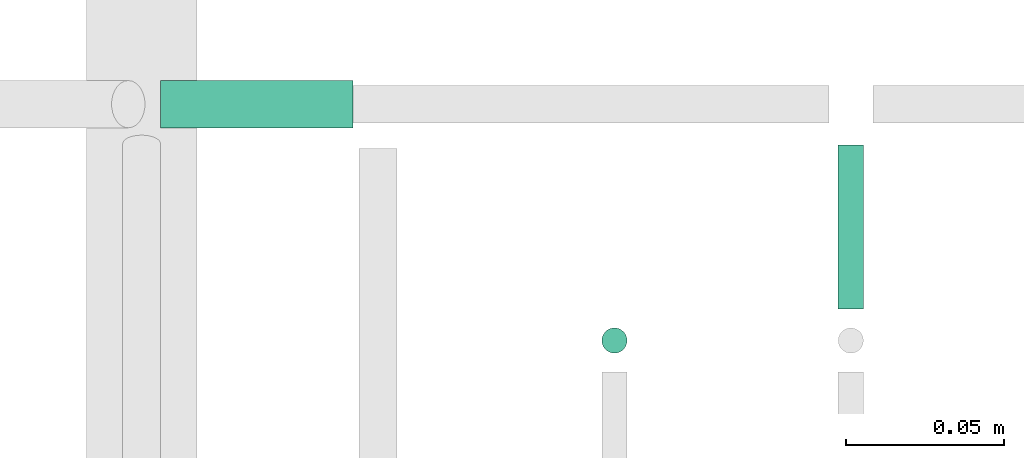
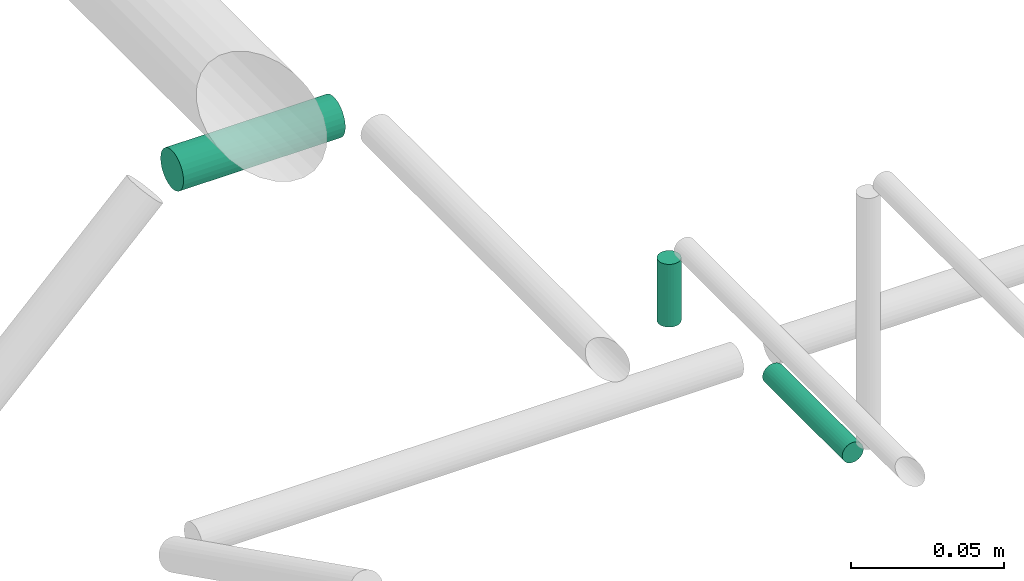
# One storey, part 254 of 331: 3 flow segments.
"""IFC2X3 building model written with IfcOpenShell, lengths in millimetres."""

from ifc_helpers import new_model, entity, si_unit, converted_unit, derived_unit, direction, frame, frame_2d, origin, origin_2d_with_axis, place, context, subcontext, project, spatial, circle, extrude, type_object, element, save


model = new_model("IFC2X3")

# Units and contexts
model_context = context("Model", 3, precision=0.01, world=origin(), true_north=direction((6.12303176911189e-17, 1.0)))
body_context = subcontext(model_context, "Body", "Model", "MODEL_VIEW")
ifc_project = project(units=[si_unit("LENGTHUNIT", "METRE", prefix="MILLI"), si_unit("AREAUNIT", "SQUARE_METRE"), si_unit("VOLUMEUNIT", "CUBIC_METRE"), converted_unit("PLANEANGLEUNIT", "DEGREE", entity("IfcRatioMeasure", 0.0174532925199433), si_unit("PLANEANGLEUNIT", "RADIAN"), dimensions=[0, 0, 0, 0, 0, 0, 0]), si_unit("MASSUNIT", "GRAM", prefix="KILO"), derived_unit("MASSDENSITYUNIT", [(si_unit("MASSUNIT", "GRAM", prefix="KILO"), 1), (si_unit("LENGTHUNIT", "METRE"), -3)]), derived_unit("MOMENTOFINERTIAUNIT", [(si_unit("LENGTHUNIT", "METRE"), 4)]), si_unit("TIMEUNIT", "SECOND"), si_unit("FREQUENCYUNIT", "HERTZ"), si_unit("THERMODYNAMICTEMPERATUREUNIT", "DEGREE_CELSIUS"), derived_unit("THERMALTRANSMITTANCEUNIT", [(si_unit("MASSUNIT", "GRAM", prefix="KILO"), 1), (si_unit("THERMODYNAMICTEMPERATUREUNIT", "KELVIN"), -1), (si_unit("TIMEUNIT", "SECOND"), -3)]), derived_unit("VOLUMETRICFLOWRATEUNIT", [(si_unit("LENGTHUNIT", "METRE"), 3), (si_unit("TIMEUNIT", "SECOND"), -1)]), derived_unit("MASSFLOWRATEUNIT", [(si_unit("MASSUNIT", "GRAM", prefix="KILO"), 1), (si_unit("TIMEUNIT", "SECOND"), -1)]), derived_unit("ROTATIONALFREQUENCYUNIT", [(si_unit("TIMEUNIT", "SECOND"), -1)]), si_unit("ELECTRICCURRENTUNIT", "AMPERE"), si_unit("ELECTRICVOLTAGEUNIT", "VOLT"), si_unit("POWERUNIT", "WATT"), si_unit("FORCEUNIT", "NEWTON", prefix="KILO"), si_unit("ILLUMINANCEUNIT", "LUX"), si_unit("LUMINOUSFLUXUNIT", "LUMEN"), si_unit("LUMINOUSINTENSITYUNIT", "CANDELA"), derived_unit("USERDEFINED", [(si_unit("MASSUNIT", "GRAM", prefix="KILO"), -1), (si_unit("LENGTHUNIT", "METRE"), -2), (si_unit("TIMEUNIT", "SECOND"), 3), (si_unit("LUMINOUSFLUXUNIT", "LUMEN"), 1)]), derived_unit("LINEARVELOCITYUNIT", [(si_unit("LENGTHUNIT", "METRE"), 1), (si_unit("TIMEUNIT", "SECOND"), -1)]), si_unit("PRESSUREUNIT", "PASCAL"), derived_unit("USERDEFINED", [(si_unit("LENGTHUNIT", "METRE"), -2), (si_unit("MASSUNIT", "GRAM", prefix="KILO"), 1), (si_unit("TIMEUNIT", "SECOND"), -2)]), derived_unit("LINEARFORCEUNIT", [(si_unit("MASSUNIT", "GRAM", prefix="KILO"), 1), (si_unit("LENGTHUNIT", "METRE"), 1), (si_unit("TIMEUNIT", "SECOND"), -2), (si_unit("LENGTHUNIT", "METRE"), -1)]), derived_unit("PLANARFORCEUNIT", [(si_unit("MASSUNIT", "GRAM", prefix="KILO"), 1), (si_unit("LENGTHUNIT", "METRE"), 1), (si_unit("TIMEUNIT", "SECOND"), -2), (si_unit("LENGTHUNIT", "METRE"), -2)])], contexts=[model_context])

# Site, building, storey
site_placement = place(None, frame((0.0, -0.00077364408347762, 0.0)))
site = spatial("IfcSite", under=ifc_project, at=site_placement, CompositionType="ELEMENT")
building_placement = place(site_placement, origin())
building = spatial("IfcBuilding", under=site, at=building_placement, CompositionType="ELEMENT")
storey_placement = place(building_placement, origin())
storey = spatial("IfcBuildingStorey", under=building, at=storey_placement, CompositionType="ELEMENT", Elevation=0.0)

# Flow segments
pipe_segment_type = type_object("IfcPipeSegmentType", PredefinedType="NOTDEFINED")
flow_segment_1_placement = place(storey_placement, frame((20627.328927594, 9265.9047277642, 18590.9047277647)))
element("IfcFlowSegment", 1, at=flow_segment_1_placement, inside=storey, type_object=pipe_segment_type, context=body_context, shape_type="SweptSolid", body=[
    extrude(circle(Radius=7.5, at=origin_2d_with_axis()), frame((0.0, 9.09527223591636, 9.09527223591636), z_axis=(1.0, 0.0, 0.0), x_axis=(0.0, -1.0, 0.0)), (0.0, 0.0, 1.0), 61.0000000000165),
])
flow_segment_2_placement = place(storey_placement, frame((20765.7336553581, 9194.40472776416, 18535.0)))
element("IfcFlowSegment", 2, at=flow_segment_2_placement, inside=storey, type_object=pipe_segment_type, context=body_context, shape_type="SweptSolid", body=[
    extrude(circle(Radius=4.0, at=frame_2d((0.0, -1.08286712929839e-12), x_axis=(1.0, 0.0))), frame((5.59527223591499, 5.59527223591716, 0.0)), (0.0, 0.0, 1.0), 25.0000000000203),
])
flow_segment_3_placement = place(building_placement, frame((20840.733655358, 9210.0, 18444.4047277641)))
element("IfcFlowSegment", 3, at=flow_segment_3_placement, inside=storey, type_object=pipe_segment_type, context=body_context, shape_type="SweptSolid", body=[
    extrude(circle(Radius=4.0, at=frame_2d((-4.33146851719357e-12, 0.0), x_axis=(1.0, 0.0))), frame((5.59527223591499, 0.0, 5.59527223591499), z_axis=(0.0, 1.0, 0.0), x_axis=(-1.0, 0.0, 0.0)), (0.0, 0.0, 1.0), 51.9999999999925),
])

save(model, "model.ifc")
